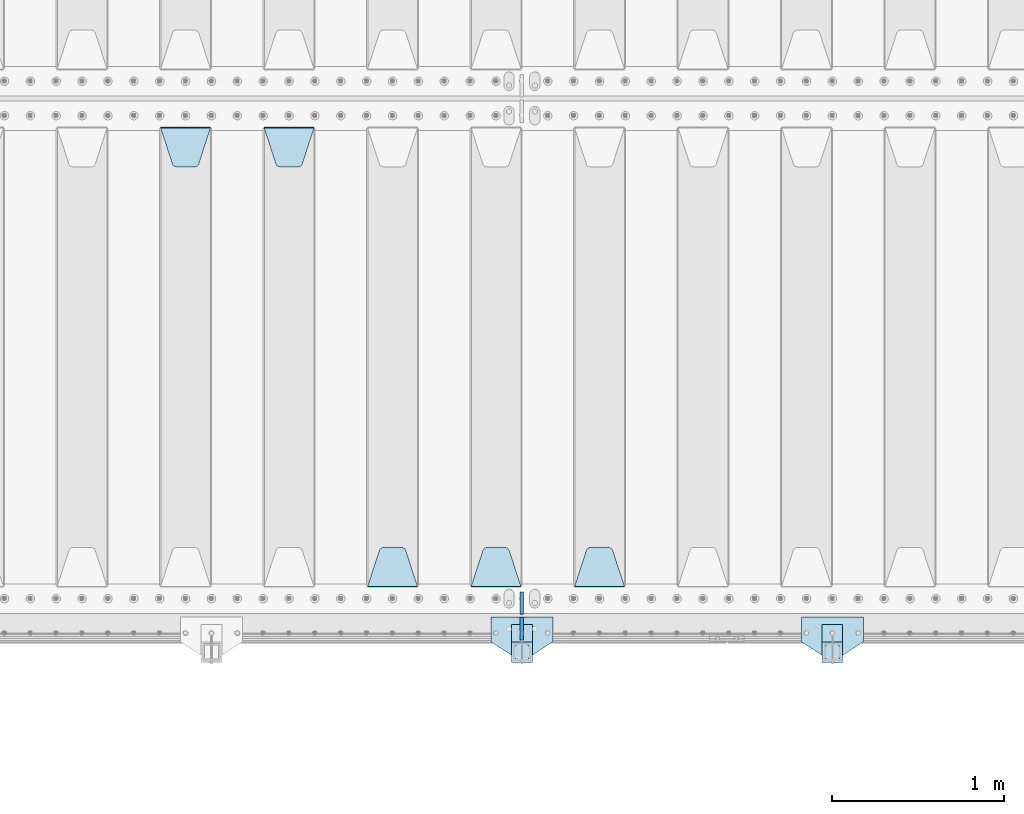
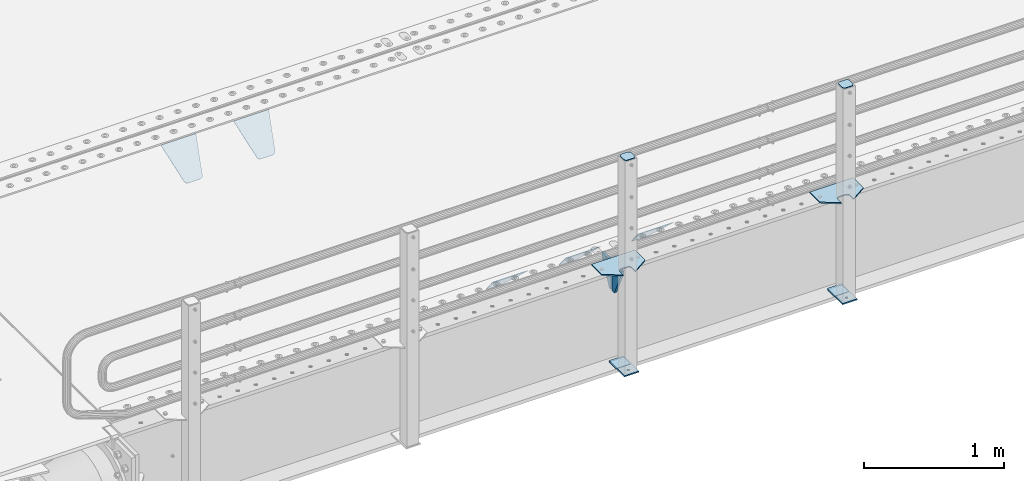
# One storey, part 192 of 240: 15 plates.
"""IFC2X3 building model written with IfcOpenShell, lengths in millimetres."""

import ifcopenshell
import ifcopenshell.guid

model = None  # the IFC model being written
_history = None  # IfcOwnerHistory: only IFC2X3 demands one
_inside = {}  # id of a spatial element -> (the spatial element, [elements in it])
_under = {}  # id of a project, library or spatial element -> (it, [spatial elements below it])
_declared = {}  # id of a project -> (the project, [libraries it declares])
_typed = {}  # id of a type object -> (the type object, [elements of that type])
_made_of = {}  # id of a material, layer set ... -> (it, [elements and type objects made of it])


def new_model(schema):
    """Start an empty IFC model of exactly this schema.

    Asked for "IFC4X3", IfcOpenShell would pick the latest addendum, in which some entities
    have other attributes; the version numbers below select the first issue.
    IFC2X3 requires an IfcOwnerHistory on every rooted entity: one is made here for all.
    """
    global model, _history
    if schema == "IFC4X3":
        model = ifcopenshell.file(schema_version=(4, 3, 0, 0))
    else:
        model = ifcopenshell.file(schema=schema)
    _inside.clear()
    _under.clear()
    _declared.clear()
    _typed.clear()
    _made_of.clear()
    _history = None
    if model.schema == "IFC2X3":
        org = make("IfcOrganization", Name="unknown")
        user = make(
            "IfcPersonAndOrganization",
            ThePerson=make("IfcPerson", FamilyName="unknown"),
            TheOrganization=org,
        )
        app = make(
            "IfcApplication",
            ApplicationDeveloper=org,
            Version="unknown",
            ApplicationFullName="unknown",
            ApplicationIdentifier="unknown",
        )
        _history = make(
            "IfcOwnerHistory",
            OwningUser=user,
            OwningApplication=app,
            ChangeAction="ADDED",
            CreationDate=0,
        )
    return model


def make(cls, **values):
    """One entity of the class cls with the attributes given. An attribute that is None is left unset."""
    return model.create_entity(
        cls, **{name: value for name, value in values.items() if value is not None}
    )


def rooted(cls, **values):
    """An entity with a GlobalId (a new one), such as an element, a storey or a relation."""
    return make(cls, GlobalId=ifcopenshell.guid.new(), OwnerHistory=_history, **values)


def si_unit(unit_type, name, prefix=None):
    """IfcSIUnit, for example si_unit("LENGTHUNIT", "METRE", prefix="MILLI")."""
    return make("IfcSIUnit", UnitType=unit_type, Prefix=prefix, Name=name)


def assignment(units):
    """IfcUnitAssignment: the units of a project."""
    return None if units is None else make("IfcUnitAssignment", Units=units)


def point(xyz):
    """IfcCartesianPoint."""
    return None if xyz is None else make("IfcCartesianPoint", Coordinates=xyz)


def direction(xyz):
    """IfcDirection."""
    return None if xyz is None else make("IfcDirection", DirectionRatios=xyz)


def frame(location, z_axis=None, x_axis=None):
    """IfcAxis2Placement3D, a coordinate frame: its origin and axes. An axis left out is left unset."""
    return make(
        "IfcAxis2Placement3D",
        Location=point(location),
        Axis=direction(z_axis),
        RefDirection=direction(x_axis),
    )


def origin_with_axes():
    """The frame at (0, 0, 0) with the z axis (0, 0, 1) and the x axis (1, 0, 0) written out."""
    return frame((0.0, 0.0, 0.0), z_axis=(0.0, 0.0, 1.0), x_axis=(1.0, 0.0, 0.0))


def place(relative_to, where):
    """IfcLocalPlacement: puts the frame where relative to a parent placement (None: the world)."""
    return make(
        "IfcLocalPlacement", PlacementRelTo=relative_to, RelativePlacement=where
    )


def context(
    kind, dimensions, precision=None, world=None, true_north=None, identifier=None
):
    """IfcGeometricRepresentationContext, for example the 3D "Model" context."""
    return make(
        "IfcGeometricRepresentationContext",
        ContextIdentifier=identifier,
        ContextType=kind,
        CoordinateSpaceDimension=dimensions,
        Precision=precision,
        WorldCoordinateSystem=world,
        TrueNorth=true_north,
    )


def subcontext(parent, identifier, kind, view, scale=None):
    """IfcGeometricRepresentationSubContext, for example "Body" below "Model"."""
    return make(
        "IfcGeometricRepresentationSubContext",
        ContextIdentifier=identifier,
        ContextType=kind,
        ParentContext=parent,
        TargetScale=scale,
        TargetView=view,
    )


def project(units=None, contexts=None):
    """IfcProject with its units and contexts."""
    return rooted(
        "IfcProject",
        Name="project",
        RepresentationContexts=contexts,
        UnitsInContext=assignment(units),
    )


def spatial(cls, under=None, at=None, **own):
    """A site, building, storey or space (cls), placed at a placement, below another one or the project."""
    s = rooted(cls, ObjectPlacement=at, **own)
    if under is not None:
        _under.setdefault(under.id(), (under, []))[1].append(s)
    return s


def faces_of(points, faces, orient=None, outer=None):
    """IfcFace entities. A face is a list of loops; a loop is a list of indices into points, from 0.

    orient and outer hold one flag for each loop. By default every Orientation is true, the
    first loop of a face is its IfcFaceOuterBound and the others are IfcFaceBound.
    """
    made = []
    for i, loops in enumerate(faces):
        bounds = []
        for j, loop in enumerate(loops):
            is_outer = j == 0 if outer is None else outer[i][j]
            bounds.append(
                make(
                    "IfcFaceOuterBound" if is_outer else "IfcFaceBound",
                    Bound=make("IfcPolyLoop", Polygon=[points[k] for k in loop]),
                    Orientation=True if orient is None else orient[i][j],
                )
            )
        made.append(make("IfcFace", Bounds=bounds))
    return made


def faceted_brep(points, faces, orient=None, outer=None, voids=None):
    """IfcFacetedBrep: a solid bounded by flat faces; with voids (closed shells), ...WithVoids."""
    shared = [point(p) for p in points]
    hull = make("IfcClosedShell", CfsFaces=faces_of(shared, faces, orient, outer))
    if voids is None:
        return make("IfcFacetedBrep", Outer=hull)
    return make(
        "IfcFacetedBrepWithVoids",
        Outer=hull,
        Voids=[
            make(cls, CfsFaces=faces_of(shared, fs, o, b)) for cls, fs, o, b in voids
        ],
    )


def shape(context_of_items, identifier, shape_type, items):
    """IfcShapeRepresentation: the items that make up one representation, for example the "Body"."""
    return make(
        "IfcShapeRepresentation",
        ContextOfItems=context_of_items,
        RepresentationIdentifier=identifier,
        RepresentationType=shape_type,
        Items=items,
    )


def material(Name=None, Category=None):
    """IfcMaterial."""
    return make("IfcMaterial", Name=Name, Category=Category)


def made_of(thing, what):
    """Note that an element or type object is made of a material, layer set ...; save() writes the relation."""
    if what is not None:
        _made_of.setdefault(what.id(), (what, []))[1].append(thing)
    return thing


def type_object(cls, material=None, **own):
    """A type object (cls), such as IfcWallType, which elements share."""
    return made_of(rooted(cls, **own), material)


def element(
    cls,
    number,
    at=None,
    inside=None,
    cuts=None,
    type_object=None,
    material=None,
    context=None,
    identifier="Body",
    shape_type=None,
    held_by="IfcProductDefinitionShape",
    body=None,
    shapes=None,
    **own,
):
    """One element of the class cls, such as IfcWall. Its Tag is "e" and its number.

    at: its placement. inside: the storey or other place that contains it. cuts: it is an
    opening in that element (IfcRelVoidsElement). A single representation is given by context,
    identifier, shape_type and body (its items); several are given by shapes. held_by: the class
    of the entity that holds the representations. save() writes the other relations.
    """
    e = rooted(cls, Tag="e%d" % number, ObjectPlacement=at, **own)
    if body is not None:
        shapes = [shape(context, identifier, shape_type, body)]
    if shapes is not None:
        e.Representation = make(held_by, Representations=shapes)
    if inside is not None:
        _inside.setdefault(inside.id(), (inside, []))[1].append(e)
    if cuts is not None:
        rooted(
            "IfcRelVoidsElement", RelatingBuildingElement=cuts, RelatedOpeningElement=e
        )
    if type_object is not None:
        _typed.setdefault(type_object.id(), (type_object, []))[1].append(e)
    return made_of(e, material)


def aggregate(whole, parts):
    """IfcRelAggregates: a whole, such as a stair, and the parts it consists of."""
    return rooted("IfcRelAggregates", RelatingObject=whole, RelatedObjects=parts)


def save(model, path):
    """Write the relations noted so far, then the file.

    IfcRelAggregates (storeys below a building ...), IfcRelContainedInSpatialStructure (elements
    in a storey), IfcRelDefinesByType, IfcRelAssociatesMaterial and IfcRelDeclares: one each for
    every whole, place, type object, material and project.
    """
    for whole, parts in _under.values():
        aggregate(whole, parts)
    for where, things in _inside.values():
        rooted(
            "IfcRelContainedInSpatialStructure",
            RelatedElements=things,
            RelatingStructure=where,
        )
    for kind, things in _typed.values():
        rooted("IfcRelDefinesByType", RelatedObjects=things, RelatingType=kind)
    for what, things in _made_of.values():
        rooted("IfcRelAssociatesMaterial", RelatedObjects=things, RelatingMaterial=what)
    for by, libraries in _declared.values():
        rooted("IfcRelDeclares", RelatingContext=by, RelatedDefinitions=libraries)
    model.write(path)


model = new_model("IFC2X3")

# Units and contexts
model_context = context("Model", 3, precision=1e-05, world=origin_with_axes())
body_context = subcontext(model_context, "Body", "Model", "MODEL_VIEW")
ifc_project = project(units=[si_unit("LENGTHUNIT", "METRE", prefix="MILLI"), si_unit("AREAUNIT", "SQUARE_METRE"), si_unit("VOLUMEUNIT", "CUBIC_METRE"), si_unit("MASSUNIT", "GRAM", prefix="KILO"), si_unit("TIMEUNIT", "SECOND"), si_unit("PLANEANGLEUNIT", "RADIAN"), si_unit("SOLIDANGLEUNIT", "STERADIAN"), si_unit("THERMODYNAMICTEMPERATUREUNIT", "DEGREE_CELSIUS"), si_unit("LUMINOUSINTENSITYUNIT", "LUMEN")], contexts=[model_context])

# Site, building, storey
site_placement = place(None, origin_with_axes())
site = spatial("IfcSite", under=ifc_project, at=site_placement, CompositionType="ELEMENT")
building_placement = place(site_placement, origin_with_axes())
building = spatial("IfcBuilding", under=site, at=building_placement, Name="Standard", CompositionType="ELEMENT")
storey_placement = place(building_placement, origin_with_axes())
storey = spatial("IfcBuildingStorey", under=building, at=storey_placement, Name="Undefined", CompositionType="ELEMENT", Elevation=0.0)

# Plates
ifc_material_1 = material(Name="STEEL/S355N")
plate_type_1 = type_object("IfcPlateType", PredefinedType="NOTDEFINED")
plate_1_placement = place(storey_placement, frame((47195.0, 24168.232233047, -1.76776695296758), z_axis=(0.0, 0.707106781186547, -0.707106781186548), x_axis=(-1.0, 0.0, 0.0)))
element("IfcPlate", 1, at=plate_1_placement, inside=storey, type_object=plate_type_1, material=ifc_material_1, context=body_context, shape_type="Brep", body=[
    faceted_brep([(0.0, -2.5, 0.0), (69.345504679477, -2.50000000000364, 300.171731424827), (69.345504679477, 2.49999999999636, 300.171731424827), (0.0, 2.5, 0.0), (70.927406119954, -2.50000000000364, 304.897442415397), (70.927406119954, 2.49999999999636, 304.897442415397), (73.3818627772271, -2.50000000000728, 309.234538108525), (73.3818627772271, 2.49999999999636, 309.234538108529), (76.6187032999587, -2.50000000000728, 313.023683126099), (76.6187032999587, 2.49999999999636, 313.023683126103), (80.5190132705029, -2.50000000000364, 316.125672595368), (80.5190132705029, 2.49999999999636, 316.125672595368), (84.9395038596849, -2.50000000000364, 318.426546230472), (84.9395038596849, 2.49999999999636, 318.426546230472), (89.7177759439219, -2.5, 319.841774983277), (89.7177759439219, 2.49999999999636, 319.841774983273), (94.6782862926484, -2.50000000000364, 320.319366455074), (94.6782862926484, 2.49999999999636, 320.319366455074), (195.321713707352, -2.50000000000364, 320.319366455074), (195.321713707352, 2.49999999999636, 320.319366455074), (200.282224056078, -2.50000000000364, 319.841774983273), (200.282224056078, 2.49999999999636, 319.841774983273), (205.060496140315, -2.50000000000364, 318.426546230472), (205.060496140315, 2.49999999999636, 318.426546230472), (209.480986729497, -2.50000000000364, 316.125672595368), (209.480986729497, 2.49999999999636, 316.125672595368), (213.381296700041, -2.50000000000728, 313.023683126099), (213.381296700041, 2.49999999999272, 313.023683126099), (216.618137222766, -2.50000000000364, 309.234538108522), (216.618137222766, 2.49999999999636, 309.234538108522), (219.072593880039, -2.50000000000364, 304.897442415397), (219.072593880039, 2.49999999999636, 304.897442415397), (220.654495320523, -2.50000000000364, 300.171731424827), (220.654495320523, 2.49999999999636, 300.171731424827), (290.0, -2.50000000000364, -3.63797880709171e-12), (290.0, 2.49999999999636, -3.63797880709171e-12)], [[[0, 1, 2, 3]], [[1, 4, 5, 2]], [[4, 6, 7, 5]], [[6, 8, 9, 7]], [[8, 10, 11, 9]], [[10, 12, 13, 11]], [[12, 14, 15, 13]], [[14, 16, 17, 15]], [[16, 18, 19, 17]], [[18, 20, 21, 19]], [[20, 22, 23, 21]], [[22, 24, 25, 23]], [[24, 26, 27, 25]], [[26, 28, 29, 27]], [[28, 30, 31, 29]], [[30, 32, 33, 31]], [[32, 34, 35, 33]], [[34, 0, 3, 35]], [[5, 7, 9, 11, 13, 15, 17, 19, 21, 23, 25, 27, 29, 31, 33, 35, 3, 2]], [[34, 32, 30, 28, 26, 24, 22, 20, 18, 16, 14, 12, 10, 8, 6, 4, 1, 0]]]),
])
plate_2_placement = place(storey_placement, frame((46595.0, 24168.232233047, -1.76776695296758), z_axis=(0.0, 0.707106781186547, -0.707106781186548), x_axis=(-1.0, 0.0, 0.0)))
element("IfcPlate", 2, at=plate_2_placement, inside=storey, type_object=plate_type_1, material=ifc_material_1, context=body_context, shape_type="Brep", body=[
    faceted_brep([(0.0, -2.5, 0.0), (69.345504679477, -2.50000000000364, 300.171731424827), (69.345504679477, 2.49999999999636, 300.171731424827), (0.0, 2.5, 0.0), (70.927406119954, -2.50000000000364, 304.897442415397), (70.927406119954, 2.49999999999636, 304.897442415397), (73.3818627772271, -2.50000000000728, 309.234538108525), (73.3818627772271, 2.49999999999636, 309.234538108529), (76.6187032999587, -2.50000000000728, 313.023683126099), (76.6187032999587, 2.49999999999636, 313.023683126103), (80.5190132705029, -2.50000000000364, 316.125672595368), (80.5190132705029, 2.49999999999636, 316.125672595368), (84.9395038596849, -2.50000000000364, 318.426546230472), (84.9395038596849, 2.49999999999636, 318.426546230472), (89.7177759439219, -2.5, 319.841774983277), (89.7177759439219, 2.49999999999636, 319.841774983273), (94.6782862926484, -2.50000000000364, 320.319366455074), (94.6782862926484, 2.49999999999636, 320.319366455074), (195.321713707352, -2.50000000000364, 320.319366455074), (195.321713707352, 2.49999999999636, 320.319366455074), (200.282224056078, -2.50000000000364, 319.841774983273), (200.282224056078, 2.49999999999636, 319.841774983273), (205.060496140315, -2.50000000000364, 318.426546230472), (205.060496140315, 2.49999999999636, 318.426546230472), (209.480986729497, -2.50000000000364, 316.125672595368), (209.480986729497, 2.49999999999636, 316.125672595368), (213.381296700041, -2.50000000000728, 313.023683126099), (213.381296700041, 2.49999999999272, 313.023683126099), (216.618137222766, -2.50000000000364, 309.234538108522), (216.618137222766, 2.49999999999636, 309.234538108522), (219.072593880039, -2.50000000000364, 304.897442415397), (219.072593880039, 2.49999999999636, 304.897442415397), (220.654495320523, -2.50000000000364, 300.171731424827), (220.654495320523, 2.49999999999636, 300.171731424827), (290.0, -2.50000000000364, -3.63797880709171e-12), (290.0, 2.49999999999636, -3.63797880709171e-12)], [[[0, 1, 2, 3]], [[1, 4, 5, 2]], [[4, 6, 7, 5]], [[6, 8, 9, 7]], [[8, 10, 11, 9]], [[10, 12, 13, 11]], [[12, 14, 15, 13]], [[14, 16, 17, 15]], [[16, 18, 19, 17]], [[18, 20, 21, 19]], [[20, 22, 23, 21]], [[22, 24, 25, 23]], [[24, 26, 27, 25]], [[26, 28, 29, 27]], [[28, 30, 31, 29]], [[30, 32, 33, 31]], [[32, 34, 35, 33]], [[34, 0, 3, 35]], [[5, 7, 9, 11, 13, 15, 17, 19, 21, 23, 25, 27, 29, 31, 33, 35, 3, 2]], [[34, 32, 30, 28, 26, 24, 22, 20, 18, 16, 14, 12, 10, 8, 6, 4, 1, 0]]]),
])
plate_3_placement = place(storey_placement, frame((45995.0, 24168.232233047, -1.76776695296758), z_axis=(0.0, 0.707106781186547, -0.707106781186548), x_axis=(-1.0, 0.0, 0.0)))
element("IfcPlate", 3, at=plate_3_placement, inside=storey, type_object=plate_type_1, material=ifc_material_1, context=body_context, shape_type="Brep", body=[
    faceted_brep([(0.0, -2.5, 0.0), (69.345504679477, -2.50000000000364, 300.171731424827), (69.345504679477, 2.49999999999636, 300.171731424827), (0.0, 2.5, 0.0), (70.927406119954, -2.50000000000364, 304.897442415397), (70.927406119954, 2.49999999999636, 304.897442415397), (73.3818627772271, -2.50000000000728, 309.234538108525), (73.3818627772271, 2.49999999999636, 309.234538108529), (76.6187032999587, -2.50000000000728, 313.023683126099), (76.6187032999587, 2.49999999999636, 313.023683126103), (80.5190132705029, -2.50000000000364, 316.125672595368), (80.5190132705029, 2.49999999999636, 316.125672595368), (84.9395038596849, -2.50000000000364, 318.426546230472), (84.9395038596849, 2.49999999999636, 318.426546230472), (89.7177759439219, -2.5, 319.841774983277), (89.7177759439219, 2.49999999999636, 319.841774983273), (94.6782862926484, -2.50000000000364, 320.319366455074), (94.6782862926484, 2.49999999999636, 320.319366455074), (195.321713707352, -2.50000000000364, 320.319366455074), (195.321713707352, 2.49999999999636, 320.319366455074), (200.282224056078, -2.50000000000364, 319.841774983273), (200.282224056078, 2.49999999999636, 319.841774983273), (205.060496140315, -2.50000000000364, 318.426546230472), (205.060496140315, 2.49999999999636, 318.426546230472), (209.480986729497, -2.50000000000364, 316.125672595368), (209.480986729497, 2.49999999999636, 316.125672595368), (213.381296700041, -2.50000000000728, 313.023683126099), (213.381296700041, 2.49999999999272, 313.023683126099), (216.618137222766, -2.50000000000364, 309.234538108522), (216.618137222766, 2.49999999999636, 309.234538108522), (219.072593880039, -2.50000000000364, 304.897442415397), (219.072593880039, 2.49999999999636, 304.897442415397), (220.654495320523, -2.50000000000364, 300.171731424827), (220.654495320523, 2.49999999999636, 300.171731424827), (290.0, -2.50000000000364, -3.63797880709171e-12), (290.0, 2.49999999999636, -3.63797880709171e-12)], [[[0, 1, 2, 3]], [[1, 4, 5, 2]], [[4, 6, 7, 5]], [[6, 8, 9, 7]], [[8, 10, 11, 9]], [[10, 12, 13, 11]], [[12, 14, 15, 13]], [[14, 16, 17, 15]], [[16, 18, 19, 17]], [[18, 20, 21, 19]], [[20, 22, 23, 21]], [[22, 24, 25, 23]], [[24, 26, 27, 25]], [[26, 28, 29, 27]], [[28, 30, 31, 29]], [[30, 32, 33, 31]], [[32, 34, 35, 33]], [[34, 0, 3, 35]], [[5, 7, 9, 11, 13, 15, 17, 19, 21, 23, 25, 27, 29, 31, 33, 35, 3, 2]], [[34, 32, 30, 28, 26, 24, 22, 20, 18, 16, 14, 12, 10, 8, 6, 4, 1, 0]]]),
])
plate_4_placement = place(storey_placement, frame((45105.0, 26831.767766956, -1.76776695296758), z_axis=(0.0, -0.707106781186547, -0.707106781186548), x_axis=(1.0, 0.0, 0.0)))
element("IfcPlate", 4, at=plate_4_placement, inside=storey, type_object=plate_type_1, material=ifc_material_1, context=body_context, shape_type="Brep", body=[
    faceted_brep([(0.0, -2.5, 0.0), (69.345504679477, -2.50000000000364, 300.171731424827), (69.345504679477, 2.49999999999636, 300.171731424827), (0.0, 2.5, 0.0), (70.927406119954, -2.50000000000364, 304.897442415397), (70.927406119954, 2.49999999999636, 304.897442415397), (73.3818627772271, -2.50000000000728, 309.234538108525), (73.3818627772271, 2.49999999999636, 309.234538108529), (76.6187032999587, -2.50000000000728, 313.023683126099), (76.6187032999587, 2.49999999999636, 313.023683126103), (80.5190132705029, -2.50000000000364, 316.125672595368), (80.5190132705029, 2.49999999999636, 316.125672595368), (84.9395038596849, -2.50000000000364, 318.426546230472), (84.9395038596849, 2.49999999999636, 318.426546230472), (89.7177759439219, -2.5, 319.841774983277), (89.7177759439219, 2.49999999999636, 319.841774983273), (94.6782862926484, -2.50000000000364, 320.319366455074), (94.6782862926484, 2.49999999999636, 320.319366455074), (195.321713707352, -2.50000000000364, 320.319366455074), (195.321713707352, 2.49999999999636, 320.319366455074), (200.282224056078, -2.50000000000364, 319.841774983273), (200.282224056078, 2.49999999999636, 319.841774983273), (205.060496140315, -2.50000000000364, 318.426546230472), (205.060496140315, 2.49999999999636, 318.426546230472), (209.480986729497, -2.50000000000364, 316.125672595368), (209.480986729497, 2.49999999999636, 316.125672595368), (213.381296700041, -2.50000000000728, 313.023683126099), (213.381296700041, 2.49999999999272, 313.023683126099), (216.618137222766, -2.50000000000364, 309.234538108522), (216.618137222766, 2.49999999999636, 309.234538108522), (219.072593880039, -2.50000000000364, 304.897442415397), (219.072593880039, 2.49999999999636, 304.897442415397), (220.654495320523, -2.50000000000364, 300.171731424827), (220.654495320523, 2.49999999999636, 300.171731424827), (290.0, -2.50000000000364, -3.63797880709171e-12), (290.0, 2.49999999999636, -3.63797880709171e-12)], [[[0, 1, 2, 3]], [[1, 4, 5, 2]], [[4, 6, 7, 5]], [[6, 8, 9, 7]], [[8, 10, 11, 9]], [[10, 12, 13, 11]], [[12, 14, 15, 13]], [[14, 16, 17, 15]], [[16, 18, 19, 17]], [[18, 20, 21, 19]], [[20, 22, 23, 21]], [[22, 24, 25, 23]], [[24, 26, 27, 25]], [[26, 28, 29, 27]], [[28, 30, 31, 29]], [[30, 32, 33, 31]], [[32, 34, 35, 33]], [[34, 0, 3, 35]], [[5, 7, 9, 11, 13, 15, 17, 19, 21, 23, 25, 27, 29, 31, 33, 35, 3, 2]], [[34, 32, 30, 28, 26, 24, 22, 20, 18, 16, 14, 12, 10, 8, 6, 4, 1, 0]]]),
])
plate_5_placement = place(storey_placement, frame((44505.0, 26831.767766956, -1.76776695296758), z_axis=(0.0, -0.707106781186547, -0.707106781186548), x_axis=(1.0, 0.0, 0.0)))
element("IfcPlate", 5, at=plate_5_placement, inside=storey, type_object=plate_type_1, material=ifc_material_1, context=body_context, shape_type="Brep", body=[
    faceted_brep([(0.0, -2.5, 0.0), (69.345504679477, -2.50000000000364, 300.171731424827), (69.345504679477, 2.49999999999636, 300.171731424827), (0.0, 2.5, 0.0), (70.927406119954, -2.50000000000364, 304.897442415397), (70.927406119954, 2.49999999999636, 304.897442415397), (73.3818627772271, -2.50000000000728, 309.234538108525), (73.3818627772271, 2.49999999999636, 309.234538108529), (76.6187032999587, -2.50000000000728, 313.023683126099), (76.6187032999587, 2.49999999999636, 313.023683126103), (80.5190132705029, -2.50000000000364, 316.125672595368), (80.5190132705029, 2.49999999999636, 316.125672595368), (84.9395038596849, -2.50000000000364, 318.426546230472), (84.9395038596849, 2.49999999999636, 318.426546230472), (89.7177759439219, -2.5, 319.841774983277), (89.7177759439219, 2.49999999999636, 319.841774983273), (94.6782862926484, -2.50000000000364, 320.319366455074), (94.6782862926484, 2.49999999999636, 320.319366455074), (195.321713707352, -2.50000000000364, 320.319366455074), (195.321713707352, 2.49999999999636, 320.319366455074), (200.282224056078, -2.50000000000364, 319.841774983273), (200.282224056078, 2.49999999999636, 319.841774983273), (205.060496140315, -2.50000000000364, 318.426546230472), (205.060496140315, 2.49999999999636, 318.426546230472), (209.480986729497, -2.50000000000364, 316.125672595368), (209.480986729497, 2.49999999999636, 316.125672595368), (213.381296700041, -2.50000000000728, 313.023683126099), (213.381296700041, 2.49999999999272, 313.023683126099), (216.618137222766, -2.50000000000364, 309.234538108522), (216.618137222766, 2.49999999999636, 309.234538108522), (219.072593880039, -2.50000000000364, 304.897442415397), (219.072593880039, 2.49999999999636, 304.897442415397), (220.654495320523, -2.50000000000364, 300.171731424827), (220.654495320523, 2.49999999999636, 300.171731424827), (290.0, -2.50000000000364, -3.63797880709171e-12), (290.0, 2.49999999999636, -3.63797880709171e-12)], [[[0, 1, 2, 3]], [[1, 4, 5, 2]], [[4, 6, 7, 5]], [[6, 8, 9, 7]], [[8, 10, 11, 9]], [[10, 12, 13, 11]], [[12, 14, 15, 13]], [[14, 16, 17, 15]], [[16, 18, 19, 17]], [[18, 20, 21, 19]], [[20, 22, 23, 21]], [[22, 24, 25, 23]], [[24, 26, 27, 25]], [[26, 28, 29, 27]], [[28, 30, 31, 29]], [[30, 32, 33, 31]], [[32, 34, 35, 33]], [[34, 0, 3, 35]], [[5, 7, 9, 11, 13, 15, 17, 19, 21, 23, 25, 27, 29, 31, 33, 35, 3, 2]], [[34, 32, 30, 28, 26, 24, 22, 20, 18, 16, 14, 12, 10, 8, 6, 4, 1, 0]]]),
])
plate_type_2 = type_object("IfcPlateType", PredefinedType="NOTDEFINED")
for number, where, z_axis, x_axis in (
    (6, (46600.0, 24140.0, -30.0), (0.0, 0.0, -1.0), (0.0, -1.0, 0.0)),
    (7, (46600.0, 23860.0, -30.0), (0.0, 0.0, -1.0), (0.0, 1.0, 0.0)),
):
    element("IfcPlate", number, at=place(storey_placement, frame(where, z_axis=z_axis, x_axis=x_axis)), inside=storey, type_object=plate_type_2, material=ifc_material_1, context=body_context, shape_type="Brep", body=[
        faceted_brep([(0.0, -10.0, 0.0), (0.0, -10.0, 30.0), (0.0, 10.0, 30.0), (0.0, 10.0, 0.0), (102.0, -10.0, 250.0), (102.0, 10.0, 250.0), (132.0, -10.0, 250.0), (132.0, 10.0, 250.0), (132.0, -10.0, 30.0), (132.0, 10.0, 30.0), (131.544232590368, -10.0, 24.790554669992), (131.544232590368, 10.0, 24.790554669992), (130.190778623579, -10.0, 19.7393957002299), (130.190778623579, 10.0, 19.7393957002299), (127.980762113533, -10.0, 15.0), (127.980762113533, 10.0, 15.0), (124.98133329357, -10.0, 10.7163717094038), (124.98133329357, 10.0, 10.7163717094038), (121.283628290596, -10.0, 7.01866670643062), (121.283628290596, 10.0, 7.01866670643062), (117.0, -10.0, 4.01923788646684), (117.0, 10.0, 4.01923788646684), (112.260604299769, -10.0, 1.80922137642278), (112.260604299769, 10.0, 1.80922137642278), (107.209445330009, -10.0, 0.455767409633722), (107.209445330009, 10.0, 0.455767409633722), (102.0, -10.0, 0.0), (102.0, 10.0, 0.0)], [[[0, 1, 2, 3]], [[1, 4, 5, 2]], [[4, 6, 7, 5]], [[6, 8, 9, 7]], [[8, 10, 11, 9]], [[10, 12, 13, 11]], [[12, 14, 15, 13]], [[14, 16, 17, 15]], [[16, 18, 19, 17]], [[18, 20, 21, 19]], [[20, 22, 23, 21]], [[22, 24, 25, 23]], [[24, 26, 27, 25]], [[26, 0, 3, 27]], [[5, 7, 9, 11, 13, 15, 17, 19, 21, 23, 25, 27, 3, 2]], [[26, 24, 22, 20, 18, 16, 14, 12, 10, 8, 6, 4, 1, 0]]]),
    ])
ifc_material_2 = material(Name="STEEL/S355J2")
plate_type_3 = type_object("IfcPlateType", PredefinedType="NOTDEFINED")
plate_6_placement = place(storey_placement, frame((48580.0, 23995.0, 5.00000000004911), z_axis=(0.0, -1.0, 0.0), x_axis=(-1.0, 0.0, 0.0)))
element("IfcPlate", 8, at=plate_6_placement, inside=storey, type_object=plate_type_3, material=ifc_material_2, context=body_context, shape_type="Brep", body=[
    faceted_brep([(0.0, -5.0, 0.0), (2.31396552408114e-06, -5.0, 145.0), (2.31396552408114e-06, 5.0, 145.0), (0.0, 5.0, 0.0), (130.0, -5.0, 230.0), (130.0, 5.0, 230.0), (130.0, -5.0, 180.0), (130.0, 5.0, 180.0), (130.48036798992, -5.0, 175.122741949599), (130.48036798992, 5.0, 175.122741949599), (131.903011687216, -5.0, 170.432914190875), (131.903011687216, 5.0, 170.432914190875), (134.213259692435, -5.0, 166.110744174512), (134.213259692435, 5.0, 166.110744174512), (137.322330470335, -5.0, 162.322330470335), (137.322330470335, 5.0, 162.322330470335), (141.110744174512, -5.0, 159.213259692435), (141.110744174512, 5.0, 159.213259692435), (145.432914190875, -5.0, 156.903011687216), (145.432914190875, 5.0, 156.903011687216), (150.122741949599, -5.0, 155.48036798992), (150.122741949599, 5.0, 155.48036798992), (155.0, -5.0, 155.0), (155.0, 5.0, 155.0), (205.0, -5.0, 155.0), (205.0, 5.0, 155.0), (209.877258050401, -5.0, 155.48036798992), (209.877258050401, 5.0, 155.48036798992), (214.567085809125, -5.0, 156.903011687216), (214.567085809125, 5.0, 156.903011687216), (218.889255825488, -5.0, 159.213259692435), (218.889255825488, 5.0, 159.213259692435), (222.677669529665, -5.0, 162.322330470335), (222.677669529665, 5.0, 162.322330470335), (225.786740307565, -5.0, 166.110744174512), (225.786740307565, 5.0, 166.110744174512), (228.096988312784, -5.0, 170.432914190875), (228.096988312784, 5.0, 170.432914190875), (229.51963201008, -5.0, 175.122741949599), (229.51963201008, 5.0, 175.122741949599), (230.0, -5.0, 180.0), (230.0, 5.0, 180.0), (230.0, -5.0, 230.0), (230.0, 5.0, 230.0), (360.0, -5.0, 145.0), (360.0, 5.0, 145.0), (360.0, -5.0, -7.27595761418343e-12), (360.0, 5.0, -7.27595761418343e-12)], [[[0, 1, 2, 3]], [[1, 4, 5, 2]], [[4, 6, 7, 5]], [[6, 8, 9, 7]], [[8, 10, 11, 9]], [[10, 12, 13, 11]], [[12, 14, 15, 13]], [[14, 16, 17, 15]], [[16, 18, 19, 17]], [[18, 20, 21, 19]], [[20, 22, 23, 21]], [[22, 24, 25, 23]], [[24, 26, 27, 25]], [[26, 28, 29, 27]], [[28, 30, 31, 29]], [[30, 32, 33, 31]], [[32, 34, 35, 33]], [[34, 36, 37, 35]], [[36, 38, 39, 37]], [[38, 40, 41, 39]], [[40, 42, 43, 41]], [[42, 44, 45, 43]], [[44, 46, 47, 45]], [[46, 0, 3, 47]], [[5, 7, 9, 11, 13, 15, 17, 19, 21, 23, 25, 27, 29, 31, 33, 35, 37, 39, 41, 43, 45, 47, 3, 2]], [[46, 44, 42, 40, 38, 36, 34, 32, 30, 28, 26, 24, 22, 20, 18, 16, 14, 12, 10, 8, 6, 4, 1, 0]]]),
])
plate_7_placement = place(storey_placement, frame((46780.0, 23995.0, 5.00000000004911), z_axis=(0.0, -1.0, 0.0), x_axis=(-1.0, 0.0, 0.0)))
element("IfcPlate", 9, at=plate_7_placement, inside=storey, type_object=plate_type_3, material=ifc_material_2, context=body_context, shape_type="Brep", body=[
    faceted_brep([(0.0, -5.0, 0.0), (2.31396552408114e-06, -5.0, 145.0), (2.31396552408114e-06, 5.0, 145.0), (0.0, 5.0, 0.0), (130.0, -5.0, 230.0), (130.0, 5.0, 230.0), (130.0, -5.0, 180.0), (130.0, 5.0, 180.0), (130.48036798992, -5.0, 175.122741949599), (130.48036798992, 5.0, 175.122741949599), (131.903011687216, -5.0, 170.432914190875), (131.903011687216, 5.0, 170.432914190875), (134.213259692435, -5.0, 166.110744174512), (134.213259692435, 5.0, 166.110744174512), (137.322330470335, -5.0, 162.322330470335), (137.322330470335, 5.0, 162.322330470335), (141.110744174512, -5.0, 159.213259692435), (141.110744174512, 5.0, 159.213259692435), (145.432914190875, -5.0, 156.903011687216), (145.432914190875, 5.0, 156.903011687216), (150.122741949599, -5.0, 155.48036798992), (150.122741949599, 5.0, 155.48036798992), (155.0, -5.0, 155.0), (155.0, 5.0, 155.0), (205.0, -5.0, 155.0), (205.0, 5.0, 155.0), (209.877258050401, -5.0, 155.48036798992), (209.877258050401, 5.0, 155.48036798992), (214.567085809125, -5.0, 156.903011687216), (214.567085809125, 5.0, 156.903011687216), (218.889255825488, -5.0, 159.213259692435), (218.889255825488, 5.0, 159.213259692435), (222.677669529665, -5.0, 162.322330470335), (222.677669529665, 5.0, 162.322330470335), (225.786740307565, -5.0, 166.110744174512), (225.786740307565, 5.0, 166.110744174512), (228.096988312784, -5.0, 170.432914190875), (228.096988312784, 5.0, 170.432914190875), (229.51963201008, -5.0, 175.122741949599), (229.51963201008, 5.0, 175.122741949599), (230.0, -5.0, 180.0), (230.0, 5.0, 180.0), (230.0, -5.0, 230.0), (230.0, 5.0, 230.0), (360.0, -5.0, 145.0), (360.0, 5.0, 145.0), (360.0, -5.0, -7.27595761418343e-12), (360.0, 5.0, -7.27595761418343e-12)], [[[0, 1, 2, 3]], [[1, 4, 5, 2]], [[4, 6, 7, 5]], [[6, 8, 9, 7]], [[8, 10, 11, 9]], [[10, 12, 13, 11]], [[12, 14, 15, 13]], [[14, 16, 17, 15]], [[16, 18, 19, 17]], [[18, 20, 21, 19]], [[20, 22, 23, 21]], [[22, 24, 25, 23]], [[24, 26, 27, 25]], [[26, 28, 29, 27]], [[28, 30, 31, 29]], [[30, 32, 33, 31]], [[32, 34, 35, 33]], [[34, 36, 37, 35]], [[36, 38, 39, 37]], [[38, 40, 41, 39]], [[40, 42, 43, 41]], [[42, 44, 45, 43]], [[44, 46, 47, 45]], [[46, 0, 3, 47]], [[5, 7, 9, 11, 13, 15, 17, 19, 21, 23, 25, 27, 29, 31, 33, 35, 37, 39, 41, 43, 45, 47, 3, 2]], [[46, 44, 42, 40, 38, 36, 34, 32, 30, 28, 26, 24, 22, 20, 18, 16, 14, 12, 10, 8, 6, 4, 1, 0]]]),
])
plate_type_4 = type_object("IfcPlateType", PredefinedType="NOTDEFINED")
for number, where, z_axis, x_axis in (
    (10, (48459.9999999999, 23949.9999999998, -850.000000000002), (0.0, -1.0, 0.0), (-1.0, 0.0, 0.0)),
    (11, (46659.9999999999, 23949.9999999998, -850.000000000002), (0.0, -1.0, 0.0), (-1.0, 0.0, 0.0)),
):
    element("IfcPlate", number, at=place(storey_placement, frame(where, z_axis=z_axis, x_axis=x_axis)), inside=storey, type_object=plate_type_4, material=ifc_material_2, context=body_context, shape_type="Brep", body=[
        faceted_brep([(53.6360389691836, -5.0, 176.363961030467), (53.6360389691836, 5.0, 176.363961030467), (59.9999999998618, 5.0, 178.999999999789), (59.9999999998618, -5.0, 178.999999999789), (66.3639610305399, 5.0, 176.363961030467), (66.3639610305399, -5.0, 176.363961030467), (68.9999999998618, 5.0, 169.999999999789), (68.9999999998618, -5.0, 169.999999999789), (66.3639610305399, 5.0, 163.636038969111), (66.3639610305399, -5.0, 163.636038969111), (59.9999999998618, 5.0, 160.999999999789), (59.9999999998618, -5.0, 160.999999999789), (53.6360389691836, 5.0, 163.636038969111), (53.6360389691836, -5.0, 163.636038969111), (50.9999999998618, 5.0, 169.999999999789), (50.9999999998618, -5.0, 169.999999999789), (120.0, -5.0, 0.0), (120.0, -5.0, 220.0), (0.0, -5.0, 220.0), (0.0, -5.0, 0.0), (0.0, 5.0, 0.0), (120.0, 5.0, 0.0), (120.0, 5.0, 220.0), (0.0, 5.0, 220.0)], [[[0, 1, 2, 3]], [[3, 2, 4, 5]], [[5, 4, 6, 7]], [[7, 6, 8, 9]], [[9, 8, 10, 11]], [[11, 10, 12, 13]], [[13, 12, 14, 15]], [[15, 14, 1, 0]], [[16, 17, 18, 19], [11, 13, 15, 0, 3, 5, 7, 9]], [[16, 19, 20, 21]], [[17, 16, 21, 22]], [[18, 17, 22, 23]], [[19, 18, 23, 20]], [[22, 21, 20, 23], [2, 1, 14, 12, 10, 8, 6, 4]]]),
    ])
plate_type_5 = type_object("IfcPlateType", PredefinedType="NOTDEFINED")
plate_8_placement = place(storey_placement, frame((48355.9999999999, 23833.9999999998, 1012.50000000001), z_axis=(0.0, -1.0, 0.0), x_axis=(1.0, 0.0, 0.0)))
element("IfcPlate", 12, at=plate_8_placement, inside=storey, type_object=plate_type_5, material=ifc_material_2, context=body_context, shape_type="Brep", body=[
    faceted_brep([(0.0, -2.5, 19.0), (0.0, -2.5, 69.0), (0.0, 2.5, 69.0), (0.0, 2.5, 19.0), (0.476369668547704, -2.5, 73.2278977451715), (0.476369668547704, 2.5, 73.2278977451715), (1.88159150985302, -2.5, 77.2437910432345), (1.88159150985302, 2.5, 77.2437910432345), (4.14520183311106, -2.5, 80.8463062353185), (4.14520183311106, 2.5, 80.8463062353185), (7.15369376468152, -2.5, 83.8547981668889), (7.15369376468152, 2.5, 83.8547981668889), (10.7562089567655, -2.5, 86.118408490147), (10.7562089567655, 2.5, 86.118408490147), (14.7721022548285, -2.5, 87.5236303314523), (14.7721022548285, 2.5, 87.5236303314523), (19.0, -2.5, 88.0), (19.0, 2.5, 88.0), (69.0, -2.5, 88.0), (69.0, 2.5, 88.0), (73.2278977451715, -2.5, 87.5236303314523), (73.2278977451715, 2.5, 87.5236303314523), (77.2437910432345, -2.5, 86.118408490147), (77.2437910432345, 2.5, 86.118408490147), (80.8463062353185, -2.5, 83.8547981668889), (80.8463062353185, 2.5, 83.8547981668889), (83.8547981668889, -2.5, 80.8463062353185), (83.8547981668889, 2.5, 80.8463062353185), (86.118408490147, -2.5, 77.2437910432345), (86.118408490147, 2.5, 77.2437910432345), (87.5236303314523, -2.5, 73.2278977451715), (87.5236303314523, 2.5, 73.2278977451715), (88.0, -2.5, 69.0), (88.0, 2.5, 69.0), (88.0, -2.5, 19.0), (88.0, 2.5, 19.0), (87.5236303314523, -2.5, 14.7721022548285), (87.5236303314523, 2.5, 14.7721022548285), (86.118408490147, -2.5, 10.7562089567655), (86.118408490147, 2.5, 10.7562089567655), (83.8547981668889, -2.5, 7.15369376468152), (83.8547981668889, 2.5, 7.15369376468152), (80.8463062353185, -2.5, 4.14520183311106), (80.8463062353185, 2.5, 4.14520183311106), (77.2437910432345, -2.5, 1.88159150985302), (77.2437910432345, 2.5, 1.88159150985302), (73.2278977451715, -2.5, 0.476369668547704), (73.2278977451715, 2.5, 0.476369668547704), (69.0, -2.5, 0.0), (69.0, 2.5, 0.0), (19.0, -2.5, 0.0), (19.0, 2.5, 0.0), (14.7721022548285, -2.5, 0.476369668547704), (14.7721022548285, 2.5, 0.476369668547704), (10.7562089567655, -2.5, 1.88159150985302), (10.7562089567655, 2.5, 1.88159150985302), (7.15369376468152, -2.5, 4.14520183311106), (7.15369376468152, 2.5, 4.14520183311106), (4.14520183311106, -2.5, 7.15369376468152), (4.14520183311106, 2.5, 7.15369376468152), (1.88159150985302, -2.5, 10.7562089567655), (1.88159150985302, 2.5, 10.7562089567655), (0.476369668547704, -2.5, 14.7721022548285), (0.476369668547704, 2.5, 14.7721022548285)], [[[0, 1, 2, 3]], [[1, 4, 5, 2]], [[4, 6, 7, 5]], [[6, 8, 9, 7]], [[8, 10, 11, 9]], [[10, 12, 13, 11]], [[12, 14, 15, 13]], [[14, 16, 17, 15]], [[16, 18, 19, 17]], [[18, 20, 21, 19]], [[20, 22, 23, 21]], [[22, 24, 25, 23]], [[24, 26, 27, 25]], [[26, 28, 29, 27]], [[28, 30, 31, 29]], [[30, 32, 33, 31]], [[32, 34, 35, 33]], [[34, 36, 37, 35]], [[36, 38, 39, 37]], [[38, 40, 41, 39]], [[40, 42, 43, 41]], [[42, 44, 45, 43]], [[44, 46, 47, 45]], [[46, 48, 49, 47]], [[48, 50, 51, 49]], [[50, 52, 53, 51]], [[52, 54, 55, 53]], [[54, 56, 57, 55]], [[56, 58, 59, 57]], [[58, 60, 61, 59]], [[60, 62, 63, 61]], [[62, 0, 3, 63]], [[5, 7, 9, 11, 13, 15, 17, 19, 21, 23, 25, 27, 29, 31, 33, 35, 37, 39, 41, 43, 45, 47, 49, 51, 53, 55, 57, 59, 61, 63, 3, 2]], [[62, 60, 58, 56, 54, 52, 50, 48, 46, 44, 42, 40, 38, 36, 34, 32, 30, 28, 26, 24, 22, 20, 18, 16, 14, 12, 10, 8, 6, 4, 1, 0]]]),
])
plate_9_placement = place(storey_placement, frame((46555.9999999999, 23833.9999999998, 1012.50000000001), z_axis=(0.0, -1.0, 0.0), x_axis=(1.0, 0.0, 0.0)))
element("IfcPlate", 13, at=plate_9_placement, inside=storey, type_object=plate_type_5, material=ifc_material_2, context=body_context, shape_type="Brep", body=[
    faceted_brep([(0.0, -2.5, 19.0), (0.0, -2.5, 69.0), (0.0, 2.5, 69.0), (0.0, 2.5, 19.0), (0.476369668547704, -2.5, 73.2278977451715), (0.476369668547704, 2.5, 73.2278977451715), (1.88159150985302, -2.5, 77.2437910432345), (1.88159150985302, 2.5, 77.2437910432345), (4.14520183311106, -2.5, 80.8463062353185), (4.14520183311106, 2.5, 80.8463062353185), (7.15369376468152, -2.5, 83.8547981668889), (7.15369376468152, 2.5, 83.8547981668889), (10.7562089567655, -2.5, 86.118408490147), (10.7562089567655, 2.5, 86.118408490147), (14.7721022548285, -2.5, 87.5236303314523), (14.7721022548285, 2.5, 87.5236303314523), (19.0, -2.5, 88.0), (19.0, 2.5, 88.0), (69.0, -2.5, 88.0), (69.0, 2.5, 88.0), (73.2278977451715, -2.5, 87.5236303314523), (73.2278977451715, 2.5, 87.5236303314523), (77.2437910432345, -2.5, 86.118408490147), (77.2437910432345, 2.5, 86.118408490147), (80.8463062353185, -2.5, 83.8547981668889), (80.8463062353185, 2.5, 83.8547981668889), (83.8547981668889, -2.5, 80.8463062353185), (83.8547981668889, 2.5, 80.8463062353185), (86.118408490147, -2.5, 77.2437910432345), (86.118408490147, 2.5, 77.2437910432345), (87.5236303314523, -2.5, 73.2278977451715), (87.5236303314523, 2.5, 73.2278977451715), (88.0, -2.5, 69.0), (88.0, 2.5, 69.0), (88.0, -2.5, 19.0), (88.0, 2.5, 19.0), (87.5236303314523, -2.5, 14.7721022548285), (87.5236303314523, 2.5, 14.7721022548285), (86.118408490147, -2.5, 10.7562089567655), (86.118408490147, 2.5, 10.7562089567655), (83.8547981668889, -2.5, 7.15369376468152), (83.8547981668889, 2.5, 7.15369376468152), (80.8463062353185, -2.5, 4.14520183311106), (80.8463062353185, 2.5, 4.14520183311106), (77.2437910432345, -2.5, 1.88159150985302), (77.2437910432345, 2.5, 1.88159150985302), (73.2278977451715, -2.5, 0.476369668547704), (73.2278977451715, 2.5, 0.476369668547704), (69.0, -2.5, 0.0), (69.0, 2.5, 0.0), (19.0, -2.5, 0.0), (19.0, 2.5, 0.0), (14.7721022548285, -2.5, 0.476369668547704), (14.7721022548285, 2.5, 0.476369668547704), (10.7562089567655, -2.5, 1.88159150985302), (10.7562089567655, 2.5, 1.88159150985302), (7.15369376468152, -2.5, 4.14520183311106), (7.15369376468152, 2.5, 4.14520183311106), (4.14520183311106, -2.5, 7.15369376468152), (4.14520183311106, 2.5, 7.15369376468152), (1.88159150985302, -2.5, 10.7562089567655), (1.88159150985302, 2.5, 10.7562089567655), (0.476369668547704, -2.5, 14.7721022548285), (0.476369668547704, 2.5, 14.7721022548285)], [[[0, 1, 2, 3]], [[1, 4, 5, 2]], [[4, 6, 7, 5]], [[6, 8, 9, 7]], [[8, 10, 11, 9]], [[10, 12, 13, 11]], [[12, 14, 15, 13]], [[14, 16, 17, 15]], [[16, 18, 19, 17]], [[18, 20, 21, 19]], [[20, 22, 23, 21]], [[22, 24, 25, 23]], [[24, 26, 27, 25]], [[26, 28, 29, 27]], [[28, 30, 31, 29]], [[30, 32, 33, 31]], [[32, 34, 35, 33]], [[34, 36, 37, 35]], [[36, 38, 39, 37]], [[38, 40, 41, 39]], [[40, 42, 43, 41]], [[42, 44, 45, 43]], [[44, 46, 47, 45]], [[46, 48, 49, 47]], [[48, 50, 51, 49]], [[50, 52, 53, 51]], [[52, 54, 55, 53]], [[54, 56, 57, 55]], [[56, 58, 59, 57]], [[58, 60, 61, 59]], [[60, 62, 63, 61]], [[62, 0, 3, 63]], [[5, 7, 9, 11, 13, 15, 17, 19, 21, 23, 25, 27, 29, 31, 33, 35, 37, 39, 41, 43, 45, 47, 49, 51, 53, 55, 57, 59, 61, 63, 3, 2]], [[62, 60, 58, 56, 54, 52, 50, 48, 46, 44, 42, 40, 38, 36, 34, 32, 30, 28, 26, 24, 22, 20, 18, 16, 14, 12, 10, 8, 6, 4, 1, 0]]]),
])
plate_type_6 = type_object("IfcPlateType", PredefinedType="NOTDEFINED")
for number, where, z_axis, x_axis in (
    (14, (48459.9999999999, 23949.9999999998, -857.500000000002), (0.0, -1.0, 0.0), (-1.0, 0.0, 0.0)),
    (15, (46659.9999999999, 23949.9999999998, -857.500000000002), (0.0, -1.0, 0.0), (-1.0, 0.0, 0.0)),
):
    element("IfcPlate", number, at=place(storey_placement, frame(where, z_axis=z_axis, x_axis=x_axis)), inside=storey, type_object=plate_type_6, material=ifc_material_2, context=body_context, shape_type="Brep", body=[
        faceted_brep([(0.0, -2.5, 0.0), (0.0, -2.5, 100.0), (0.0, 2.5, 100.0), (0.0, 2.5, 0.0), (120.0, -2.5, 100.0), (120.0, 2.5, 100.0), (120.0, -2.5, 0.0), (120.0, 2.5, 0.0)], [[[0, 1, 2, 3]], [[1, 4, 5, 2]], [[4, 6, 7, 5]], [[6, 0, 3, 7]], [[5, 7, 3, 2]], [[6, 4, 1, 0]]]),
    ])

save(model, "model.ifc")
